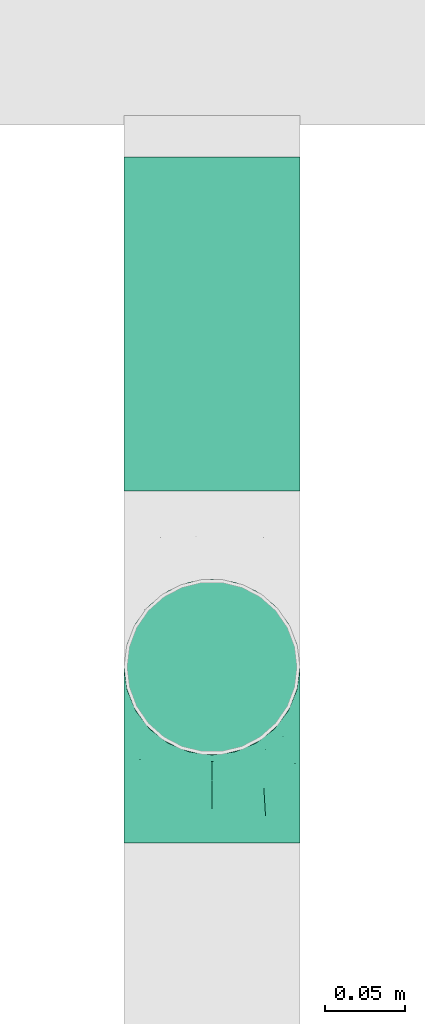
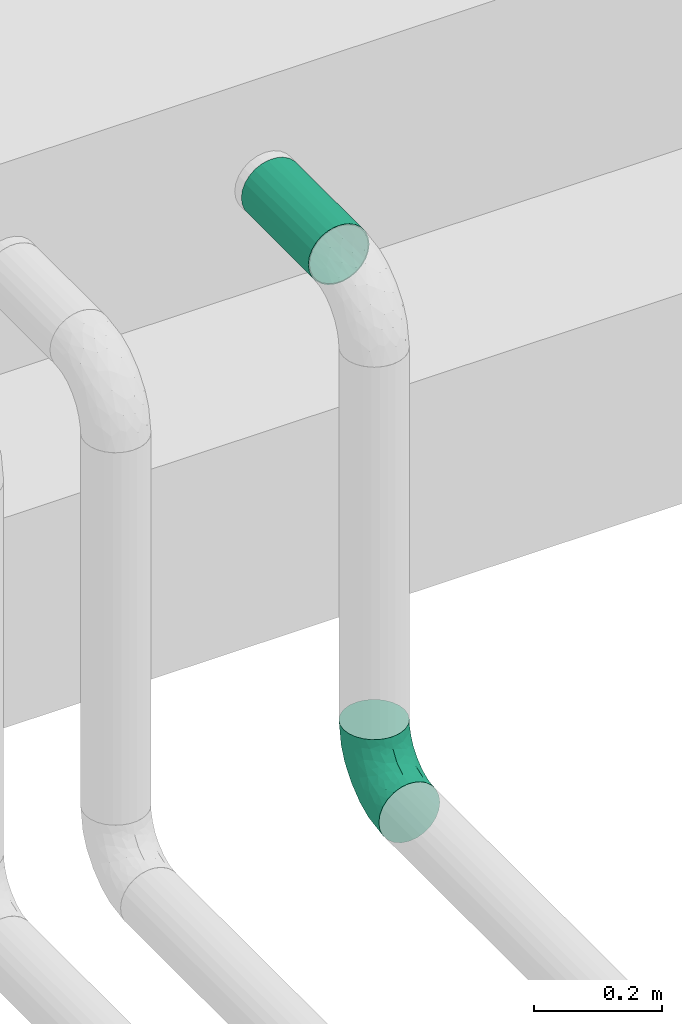
# One storey, part 58 of 91: 1 flow fitting, 1 flow segment.
"""IFC2X3 building model written with IfcOpenShell, lengths in millimetres."""

import ifcopenshell
import ifcopenshell.guid

model = None  # the IFC model being written
_history = None  # IfcOwnerHistory: only IFC2X3 demands one
_inside = {}  # id of a spatial element -> (the spatial element, [elements in it])
_under = {}  # id of a project, library or spatial element -> (it, [spatial elements below it])
_declared = {}  # id of a project -> (the project, [libraries it declares])
_typed = {}  # id of a type object -> (the type object, [elements of that type])
_made_of = {}  # id of a material, layer set ... -> (it, [elements and type objects made of it])


def new_model(schema):
    """Start an empty IFC model of exactly this schema.

    Asked for "IFC4X3", IfcOpenShell would pick the latest addendum, in which some entities
    have other attributes; the version numbers below select the first issue.
    IFC2X3 requires an IfcOwnerHistory on every rooted entity: one is made here for all.
    """
    global model, _history
    if schema == "IFC4X3":
        model = ifcopenshell.file(schema_version=(4, 3, 0, 0))
    else:
        model = ifcopenshell.file(schema=schema)
    _inside.clear()
    _under.clear()
    _declared.clear()
    _typed.clear()
    _made_of.clear()
    _history = None
    if model.schema == "IFC2X3":
        org = make("IfcOrganization", Name="unknown")
        user = make(
            "IfcPersonAndOrganization",
            ThePerson=make("IfcPerson", FamilyName="unknown"),
            TheOrganization=org,
        )
        app = make(
            "IfcApplication",
            ApplicationDeveloper=org,
            Version="unknown",
            ApplicationFullName="unknown",
            ApplicationIdentifier="unknown",
        )
        _history = make(
            "IfcOwnerHistory",
            OwningUser=user,
            OwningApplication=app,
            ChangeAction="ADDED",
            CreationDate=0,
        )
    return model


def make(cls, **values):
    """One entity of the class cls with the attributes given. An attribute that is None is left unset."""
    return model.create_entity(
        cls, **{name: value for name, value in values.items() if value is not None}
    )


def entity(cls, *values):
    """Any entity or typed value of the class cls, its attributes in the order of the schema. None: left unset."""
    e = model.create_entity(cls)
    for i, value in enumerate(values):
        if value is not None:
            e[i] = value
    return e


def rooted(cls, **values):
    """An entity with a GlobalId (a new one), such as an element, a storey or a relation."""
    return make(cls, GlobalId=ifcopenshell.guid.new(), OwnerHistory=_history, **values)


def si_unit(unit_type, name, prefix=None):
    """IfcSIUnit, for example si_unit("LENGTHUNIT", "METRE", prefix="MILLI")."""
    return make("IfcSIUnit", UnitType=unit_type, Prefix=prefix, Name=name)


def converted_unit(unit_type, name, factor, base, dimensions=None, offset=None):
    """IfcConversionBasedUnit, such as the inch: factor (a typed value) times the base unit."""
    return make(
        "IfcConversionBasedUnit"
        if offset is None
        else "IfcConversionBasedUnitWithOffset",
        ConversionOffset=offset,
        Dimensions=None
        if dimensions is None
        else entity("IfcDimensionalExponents", *dimensions),
        UnitType=unit_type,
        Name=name,
        ConversionFactor=make(
            "IfcMeasureWithUnit", ValueComponent=factor, UnitComponent=base
        ),
    )


def derived_unit(unit_type, elements):
    """IfcDerivedUnit: a product of units, each with its exponent."""
    return make(
        "IfcDerivedUnit",
        Elements=[
            make("IfcDerivedUnitElement", Unit=unit, Exponent=power)
            for unit, power in elements
        ],
        UnitType=unit_type,
    )


def assignment(units):
    """IfcUnitAssignment: the units of a project."""
    return None if units is None else make("IfcUnitAssignment", Units=units)


def point(xyz):
    """IfcCartesianPoint."""
    return None if xyz is None else make("IfcCartesianPoint", Coordinates=xyz)


def direction(xyz):
    """IfcDirection."""
    return None if xyz is None else make("IfcDirection", DirectionRatios=xyz)


def frame(location, z_axis=None, x_axis=None):
    """IfcAxis2Placement3D, a coordinate frame: its origin and axes. An axis left out is left unset."""
    return make(
        "IfcAxis2Placement3D",
        Location=point(location),
        Axis=direction(z_axis),
        RefDirection=direction(x_axis),
    )


def frame_2d(location, x_axis=None):
    """IfcAxis2Placement2D, a coordinate frame in the plane: its origin and x axis."""
    return make(
        "IfcAxis2Placement2D", Location=point(location), RefDirection=direction(x_axis)
    )


def origin_with_axes():
    """The frame at (0, 0, 0) with the z axis (0, 0, 1) and the x axis (1, 0, 0) written out."""
    return frame((0.0, 0.0, 0.0), z_axis=(0.0, 0.0, 1.0), x_axis=(1.0, 0.0, 0.0))


def origin_2d_with_axis():
    """The frame at (0, 0) in the plane with the x axis (1, 0) written out."""
    return frame_2d((0.0, 0.0), x_axis=(1.0, 0.0))


def place(relative_to, where):
    """IfcLocalPlacement: puts the frame where relative to a parent placement (None: the world)."""
    return make(
        "IfcLocalPlacement", PlacementRelTo=relative_to, RelativePlacement=where
    )


def context(
    kind, dimensions, precision=None, world=None, true_north=None, identifier=None
):
    """IfcGeometricRepresentationContext, for example the 3D "Model" context."""
    return make(
        "IfcGeometricRepresentationContext",
        ContextIdentifier=identifier,
        ContextType=kind,
        CoordinateSpaceDimension=dimensions,
        Precision=precision,
        WorldCoordinateSystem=world,
        TrueNorth=true_north,
    )


def subcontext(parent, identifier, kind, view, scale=None):
    """IfcGeometricRepresentationSubContext, for example "Body" below "Model"."""
    return make(
        "IfcGeometricRepresentationSubContext",
        ContextIdentifier=identifier,
        ContextType=kind,
        ParentContext=parent,
        TargetScale=scale,
        TargetView=view,
    )


def project(units=None, contexts=None):
    """IfcProject with its units and contexts."""
    return rooted(
        "IfcProject",
        Name="project",
        RepresentationContexts=contexts,
        UnitsInContext=assignment(units),
    )


def spatial(cls, under=None, at=None, **own):
    """A site, building, storey or space (cls), placed at a placement, below another one or the project."""
    s = rooted(cls, ObjectPlacement=at, **own)
    if under is not None:
        _under.setdefault(under.id(), (under, []))[1].append(s)
    return s


def profile(cls, at=None, kind="AREA", **sizes):
    """A parametric profile (cls). Its sizes go by their IFC names, for example OverallWidth=200.0."""
    return make(cls, ProfileType=kind, Position=at, **sizes)


def hollow_circle(**sizes):
    """IfcCircleHollowProfileDef."""
    return profile("IfcCircleHollowProfileDef", **sizes)


def extrude(swept, where, along, depth):
    """IfcExtrudedAreaSolid: the profile swept, set in the frame where, extruded along a direction by depth."""
    return make(
        "IfcExtrudedAreaSolid",
        SweptArea=swept,
        Position=where,
        ExtrudedDirection=direction(along),
        Depth=depth,
    )


def faces_of(points, faces, orient=None, outer=None):
    """IfcFace entities. A face is a list of loops; a loop is a list of indices into points, from 0.

    orient and outer hold one flag for each loop. By default every Orientation is true, the
    first loop of a face is its IfcFaceOuterBound and the others are IfcFaceBound.
    """
    made = []
    for i, loops in enumerate(faces):
        bounds = []
        for j, loop in enumerate(loops):
            is_outer = j == 0 if outer is None else outer[i][j]
            bounds.append(
                make(
                    "IfcFaceOuterBound" if is_outer else "IfcFaceBound",
                    Bound=make("IfcPolyLoop", Polygon=[points[k] for k in loop]),
                    Orientation=True if orient is None else orient[i][j],
                )
            )
        made.append(make("IfcFace", Bounds=bounds))
    return made


def open_shell(faces, orient=None, outer=None):
    """The faces of one IfcOpenShell. surface_model builds it on its shared points."""
    return ("IfcOpenShell", faces, orient, outer)


def surface_model(cls, points, shells):
    """IfcFaceBasedSurfaceModel or IfcShellBasedSurfaceModel (cls): surfaces that need not close."""
    shared = [point(p) for p in points]
    made = [make(c, CfsFaces=faces_of(shared, fs, o, b)) for c, fs, o, b in shells]
    if cls == "IfcFaceBasedSurfaceModel":
        return make(cls, FbsmFaces=made)
    return make(cls, SbsmBoundary=made)


def shape(context_of_items, identifier, shape_type, items):
    """IfcShapeRepresentation: the items that make up one representation, for example the "Body"."""
    return make(
        "IfcShapeRepresentation",
        ContextOfItems=context_of_items,
        RepresentationIdentifier=identifier,
        RepresentationType=shape_type,
        Items=items,
    )


def source(mapping_origin, context_of_items, identifier, shape_type, items):
    """IfcRepresentationMap: a shape defined once, which mapped items show again and again."""
    return make(
        "IfcRepresentationMap",
        MappingOrigin=mapping_origin,
        MappedRepresentation=shape(context_of_items, identifier, shape_type, items),
    )


def transform(
    local_origin,
    x_axis=None,
    y_axis=None,
    z_axis=None,
    scale=None,
    scale2=None,
    scale3=None,
    uniform=True,
):
    """IfcCartesianTransformationOperator3D, or its non-uniform kind. x_axis, y_axis, z_axis: its Axis1, 2, 3."""
    if uniform:
        return make(
            "IfcCartesianTransformationOperator3D",
            Axis1=direction(x_axis),
            Axis2=direction(y_axis),
            LocalOrigin=point(local_origin),
            Scale=scale,
            Axis3=direction(z_axis),
        )
    return make(
        "IfcCartesianTransformationOperator3DnonUniform",
        Axis1=direction(x_axis),
        Axis2=direction(y_axis),
        LocalOrigin=point(local_origin),
        Scale=scale,
        Axis3=direction(z_axis),
        Scale2=scale2,
        Scale3=scale3,
    )


def mapped(mapping_source, mapping_target):
    """IfcMappedItem: shows the shape of a source again, moved by a transform."""
    return make(
        "IfcMappedItem", MappingSource=mapping_source, MappingTarget=mapping_target
    )


def material(Name=None, Category=None):
    """IfcMaterial."""
    return make("IfcMaterial", Name=Name, Category=Category)


def layer(
    of_material, thickness, ventilated=None, Name=None, Category=None, Priority=None
):
    """IfcMaterialLayer: one layer of a wall or slab, of a material (None: an air gap)."""
    return make(
        "IfcMaterialLayer",
        Material=of_material,
        LayerThickness=thickness,
        IsVentilated=ventilated,
        Name=Name,
        Category=Category,
        Priority=Priority,
    )


def layer_set(layers, Name=None):
    """IfcMaterialLayerSet."""
    return make("IfcMaterialLayerSet", MaterialLayers=layers, LayerSetName=Name)


def layer_usage(for_layer_set, set_direction, sense, offset, extent=None):
    """IfcMaterialLayerSetUsage: how a layer set lies in its element."""
    return make(
        "IfcMaterialLayerSetUsage",
        ForLayerSet=for_layer_set,
        LayerSetDirection=set_direction,
        DirectionSense=sense,
        OffsetFromReferenceLine=offset,
        ReferenceExtent=extent,
    )


def made_of(thing, what):
    """Note that an element or type object is made of a material, layer set ...; save() writes the relation."""
    if what is not None:
        _made_of.setdefault(what.id(), (what, []))[1].append(thing)
    return thing


def type_object(cls, material=None, **own):
    """A type object (cls), such as IfcWallType, which elements share."""
    return made_of(rooted(cls, **own), material)


def element(
    cls,
    number,
    at=None,
    inside=None,
    cuts=None,
    type_object=None,
    material=None,
    context=None,
    identifier="Body",
    shape_type=None,
    held_by="IfcProductDefinitionShape",
    body=None,
    shapes=None,
    **own,
):
    """One element of the class cls, such as IfcWall. Its Tag is "e" and its number.

    at: its placement. inside: the storey or other place that contains it. cuts: it is an
    opening in that element (IfcRelVoidsElement). A single representation is given by context,
    identifier, shape_type and body (its items); several are given by shapes. held_by: the class
    of the entity that holds the representations. save() writes the other relations.
    """
    e = rooted(cls, Tag="e%d" % number, ObjectPlacement=at, **own)
    if body is not None:
        shapes = [shape(context, identifier, shape_type, body)]
    if shapes is not None:
        e.Representation = make(held_by, Representations=shapes)
    if inside is not None:
        _inside.setdefault(inside.id(), (inside, []))[1].append(e)
    if cuts is not None:
        rooted(
            "IfcRelVoidsElement", RelatingBuildingElement=cuts, RelatedOpeningElement=e
        )
    if type_object is not None:
        _typed.setdefault(type_object.id(), (type_object, []))[1].append(e)
    return made_of(e, material)


def aggregate(whole, parts):
    """IfcRelAggregates: a whole, such as a stair, and the parts it consists of."""
    return rooted("IfcRelAggregates", RelatingObject=whole, RelatedObjects=parts)


def save(model, path):
    """Write the relations noted so far, then the file.

    IfcRelAggregates (storeys below a building ...), IfcRelContainedInSpatialStructure (elements
    in a storey), IfcRelDefinesByType, IfcRelAssociatesMaterial and IfcRelDeclares: one each for
    every whole, place, type object, material and project.
    """
    for whole, parts in _under.values():
        aggregate(whole, parts)
    for where, things in _inside.values():
        rooted(
            "IfcRelContainedInSpatialStructure",
            RelatedElements=things,
            RelatingStructure=where,
        )
    for kind, things in _typed.values():
        rooted("IfcRelDefinesByType", RelatedObjects=things, RelatingType=kind)
    for what, things in _made_of.values():
        rooted("IfcRelAssociatesMaterial", RelatedObjects=things, RelatingMaterial=what)
    for by, libraries in _declared.values():
        rooted("IfcRelDeclares", RelatingContext=by, RelatedDefinitions=libraries)
    model.write(path)


model = new_model("IFC2X3")

# Units and contexts
model_context = context("Model", 3, precision=1e-05, world=origin_with_axes(), true_north=direction((0.0, 1.0)))
body_context = subcontext(model_context, "Body", "Model", "MODEL_VIEW")
ifc_project = project(units=[si_unit("AREAUNIT", "SQUARE_METRE"), si_unit("VOLUMEUNIT", "CUBIC_METRE", prefix="DECI"), si_unit("TIMEUNIT", "SECOND"), si_unit("THERMODYNAMICTEMPERATUREUNIT", "DEGREE_CELSIUS"), si_unit("PRESSUREUNIT", "PASCAL"), si_unit("MASSUNIT", "GRAM", prefix="KILO"), si_unit("LENGTHUNIT", "METRE", prefix="MILLI"), si_unit("POWERUNIT", "WATT"), si_unit("ELECTRICCURRENTUNIT", "AMPERE"), si_unit("ELECTRICVOLTAGEUNIT", "VOLT"), derived_unit("VOLUMETRICFLOWRATEUNIT", [(si_unit("VOLUMEUNIT", "CUBIC_METRE", prefix="DECI"), 1), (si_unit("TIMEUNIT", "SECOND"), -1)]), derived_unit("LINEARVELOCITYUNIT", [(si_unit("LENGTHUNIT", "METRE"), 1), (si_unit("TIMEUNIT", "SECOND"), -1)]), derived_unit("MASSDENSITYUNIT", [(si_unit("MASSUNIT", "GRAM", prefix="KILO"), 1), (si_unit("VOLUMEUNIT", "CUBIC_METRE"), -1)]), converted_unit("PLANEANGLEUNIT", "DEGREE", entity("IfcRatioMeasure", 0.01745), si_unit("PLANEANGLEUNIT", "RADIAN"), dimensions=[0, 0, 0, 0, 0, 0, 0])], contexts=[model_context])

# Site, building, storey
site_placement = place(None, origin_with_axes())
site = spatial("IfcSite", under=ifc_project, at=site_placement, CompositionType="ELEMENT")
building_placement = place(site_placement, origin_with_axes())
building = spatial("IfcBuilding", under=site, at=building_placement, Name="mc-building", CompositionType="ELEMENT")
storey_placement = place(building_placement, frame((0.0, 0.0, 8700.0), z_axis=(0.0, 0.0, 1.0), x_axis=(1.0, 0.0, 0.0)))
storey = spatial("IfcBuildingStorey", under=building, at=storey_placement, CompositionType="ELEMENT", Elevation=8700.0)

# Flow fitting
duct_fitting_type = type_object("IfcDuctFittingType", Name="BU", PredefinedType="BEND")
shared_shape_1 = source(origin_with_axes(), body_context, "Body", "SurfaceModel", [
    surface_model("IfcShellBasedSurfaceModel", [(-110.0, 0.0, -55.0), (-110.0, -14.23505, -53.12592), (-110.0, 14.23505, -53.12592), (-110.0, 53.12592, 14.23505), (-110.0, 27.5, -47.63139), (-110.0, 38.89087, -38.89087), (-110.0, -55.0, 0.0), (-110.0, -53.12592, 14.23505), (-110.0, -38.89087, -38.89087), (-110.0, -27.5, -47.63139), (-110.0, -53.12592, -14.23505), (-110.0, -47.63139, -27.5), (-110.0, -14.23505, 53.12592), (-110.0, 14.23505, 53.12592), (-110.0, 27.5, 47.63139), (-110.0, -47.63139, 27.5), (-110.0, -38.89087, 38.89087), (-110.0, -27.5, 47.63139), (-110.0, 0.0, 55.0), (-110.0, 55.0, 0.0), (-110.0, 53.12592, -14.23505), (-110.0, 47.63139, -27.5), (-110.0, 47.63139, 27.5), (-110.0, 38.89087, 38.89087), (-14.23505, 110.0, -53.12592), (-55.0, 110.0, 0.0), (0.0, 110.0, -55.0), (-27.5, 110.0, -47.63139), (-38.89087, 110.0, -38.89087), (-47.63139, 110.0, -27.5), (38.89087, 110.0, -38.89087), (53.12592, 110.0, 14.23505), (27.5, 110.0, -47.63139), (14.23505, 110.0, -53.12592), (47.63139, 110.0, -27.5), (53.12592, 110.0, -14.23505), (55.0, 110.0, 0.0), (-53.12592, 110.0, -14.23505), (-53.12592, 110.0, 14.23505), (-47.63139, 110.0, 27.5), (-38.89087, 110.0, 38.89087), (-27.5, 110.0, 47.63139), (0.0, 110.0, 55.0), (-14.23505, 110.0, 53.12592), (38.89087, 110.0, 38.89087), (47.63139, 110.0, 27.5), (27.5, 110.0, 47.63139), (14.23505, 110.0, 53.12592), (-64.21732, 48.68956, 43.63444), (-76.6405, 38.18013, 45.55988), (-60.44912, 32.56953, 51.94617), (-76.00813, 5.38378, 55.0), (-90.15553, 11.94394, 54.09138), (-78.5998, 26.77405, 50.81338), (-70.18771, 18.55163, 54.03432), (-75.55424, 54.2118, 32.41257), (-93.27622, 45.77614, 33.48188), (-96.12334, 22.13664, 50.81337), (-21.00813, 45.34362, 55.0), (-18.36258, 70.48427, 54.04484), (-32.04182, 59.64019, 52.24446), (-63.88653, 74.77858, 17.99134), (-74.66383, 63.08407, 19.92123), (-63.60674, 66.07878, 29.97482), (-99.597, 52.72185, 18.52927), (-93.11138, 56.59448, 10.50359), (-98.21577, 57.34403, 0.0), (-53.42855, 92.60092, 21.04759), (-88.54852, 54.8376, 21.04759), (-11.86161, 90.23965, 54.10313), (-5.38378, 76.00813, 55.0), (-57.34403, 98.21577, 0.0), (-56.64619, 93.12774, 10.22088), (-45.34362, 21.00813, 55.0), (-44.60838, 44.60838, 52.13415), (-92.68484, 35.46673, 43.63443), (-22.25266, 95.40765, 50.81337), (-35.97783, 90.61597, 43.63443), (-43.70931, 69.58671, 44.47149), (-27.23711, 77.39884, 50.81337), (-57.2828, 79.3123, 24.9774), (-58.67786, 84.31125, 16.04456), (-82.93277, 60.36161, 12.91784), (-49.88337, 54.51816, 47.224), (-74.57753, 66.83759, 9.55742), (-45.35812, 94.97281, 33.48188), (-59.18663, 88.95241, 0.0), (-51.517, 78.6292, 33.48188), (-65.14788, 80.03077, 0.0), (-56.45322, 62.06476, 39.63545), (-88.95241, 59.18663, 0.0), (-71.10913, 71.10913, 0.0), (-80.03077, 65.14788, 0.0), (-94.9309, 45.36788, -33.48188), (-93.11358, 56.60141, -10.46614), (-99.64997, 52.79499, -18.30015), (-90.20425, 36.08686, -43.63443), (-79.99933, 46.56772, -37.92748), (-76.00813, 5.38378, -55.0), (-72.75364, 19.68651, -53.60527), (-45.34362, 21.00813, -55.0), (-21.91957, 65.12078, -53.85897), (-5.38378, 76.00813, -55.0), (-21.00813, 45.34362, -55.0), (-35.41876, 92.89265, -43.63443), (-91.10309, 11.02766, -54.21832), (-45.77614, 93.27622, -33.48188), (-90.50474, 23.21022, -50.81337), (-70.92854, 33.31794, -49.51754), (-78.52933, 63.35627, -11.73997), (-24.91508, 84.05606, -50.81337), (-88.78941, 54.74452, -21.04759), (-69.59921, 57.34866, -33.48187), (-73.36422, 62.46673, -22.94182), (-63.49062, 67.59111, -28.46929), (-56.59448, 93.11138, -10.50359), (-54.8376, 88.54852, -21.04759), (-54.10679, 75.85581, -32.31867), (-57.75956, 31.09612, -52.80882), (-52.72185, 99.597, -18.52927), (-12.62913, 89.46304, -53.99097), (-34.46825, 66.46123, -50.04329), (-43.9837, 43.9837, -52.42279), (-65.78527, 72.58348, -17.68796), (-70.34468, 43.65295, -44.21951), (-57.47001, 51.99467, -44.91465), (-60.72547, 82.29174, -12.88567), (-42.34915, 74.24548, -43.63444), (-57.25194, 63.5016, -38.08211), (-80.95344, 53.56991, -29.32027), (-52.32891, 4.55257, -54.0482), (32.52942, 47.13398, -30.48571), (14.88266, 20.92917, -33.7947), (14.95561, 36.05775, -42.26543), (30.24048, 70.09027, -41.7461), (19.3559, 65.35825, -48.00507), (-70.35075, -46.44478, -19.5952), (-47.13398, -32.52942, -30.48571), (-28.49299, -30.5778, -16.4009), (-4.55257, 52.32891, -54.0482), (-22.4954, 22.4954, -53.25347), (-75.47368, -11.22546, -52.60718), (-81.32209, -51.5606, -9.98467), (-80.81763, -41.84862, -32.14655), (-70.09027, -30.24048, -41.7461), (-36.05774, -14.95561, -42.26543), (-9.15831, -10.852, -27.8997), (-65.35825, -19.3559, -48.00507), (11.22546, 75.47368, -52.60718), (3.94376, 43.9333, -50.53315), (-13.39742, 13.39743, -48.13058), (-43.9333, -3.94376, -50.53315), (49.37776, 67.29486, 0.0), (41.8609, 47.82256, -9.92641), (50.20582, 74.51695, -9.9731), (18.93131, 11.7156, -17.56239), (-27.5, -32.89419, 0.0), (-1.23348, -12.25375, -12.18106), (41.84862, 80.81763, -32.14655), (35.70604, 41.31408, -20.38235), (46.44478, 70.35075, -19.5952), (32.89419, 27.5, 0.0), (6.67262, -6.67262, 0.0), (-67.29486, -49.37776, 0.0), (-50.36265, -42.95545, -9.51562), (-5.47251, 5.47251, -39.92906), (-70.35075, -46.44478, 19.5952), (-74.51695, -50.20582, 9.9731), (-41.31407, -35.70604, 20.38235), (-47.13398, -32.52942, 30.48571), (-80.81763, -41.84862, 32.14655), (-4.55257, 52.32891, 54.0482), (11.22546, 75.47368, 52.60718), (-43.9333, -3.94376, 50.53315), (-65.35825, -19.3559, 48.00507), (-36.05774, -14.95561, 42.26543), (-70.09027, -30.24048, 41.7461), (-11.7156, -18.93131, 17.56239), (30.5778, 28.49299, 16.4009), (12.25375, 1.23348, 12.18106), (51.5606, 81.32209, 9.98467), (42.95545, 50.36265, 9.51562), (-75.47368, -11.22546, 52.60718), (-52.32891, 4.55257, 54.0482), (3.94376, 43.9333, 50.53315), (-22.4954, 22.4954, 53.25347), (-13.39742, 13.39743, 48.13058), (10.852, 9.15831, 27.8997), (-20.92916, -14.88266, 33.79469), (-47.82256, -41.8609, 9.92641), (32.52942, 47.13398, 30.48571), (46.44478, 70.35075, 19.5952), (41.84862, 80.81763, 32.14655), (30.24048, 70.09027, 41.7461), (19.3559, 65.35825, 48.00507), (14.95561, 36.05775, 42.26543), (-5.47251, 5.47251, 39.92906)], [open_shell([[[0, 1, 2]], [[2, 3, 4]], [[4, 3, 5]], [[2, 6, 7]], [[8, 6, 9]], [[1, 9, 6]], [[10, 6, 11]], [[8, 11, 6]], [[6, 2, 1]], [[12, 13, 14]], [[15, 2, 7]], [[16, 17, 2]], [[2, 17, 12]], [[12, 18, 13]], [[19, 20, 3]], [[5, 3, 21]], [[20, 21, 3]], [[22, 3, 2]], [[23, 22, 2]], [[12, 14, 2]], [[2, 14, 23]], [[15, 16, 2]], [[24, 25, 26]], [[27, 25, 24]], [[25, 28, 29]], [[28, 25, 27]], [[30, 26, 31]], [[26, 30, 32]], [[32, 33, 26]], [[34, 31, 35]], [[31, 34, 30]], [[35, 31, 36]], [[29, 37, 25]], [[38, 39, 26]], [[39, 40, 26]], [[41, 42, 40]], [[42, 26, 40]], [[42, 41, 43]], [[26, 44, 45]], [[31, 26, 45]], [[26, 46, 44]], [[47, 46, 26]], [[42, 47, 26]], [[25, 38, 26]], [[48, 49, 50]], [[18, 51, 52]], [[53, 54, 50]], [[55, 56, 49]], [[56, 22, 23]], [[13, 57, 14]], [[58, 59, 60]], [[61, 62, 63]], [[3, 64, 65]], [[53, 52, 54]], [[3, 65, 66]], [[67, 39, 38]], [[56, 68, 64]], [[65, 64, 68]], [[69, 59, 70]], [[38, 71, 72]], [[73, 58, 74]], [[75, 49, 56]], [[76, 69, 43]], [[53, 57, 52]], [[77, 78, 79]], [[41, 76, 43]], [[43, 69, 42]], [[55, 68, 56]], [[23, 14, 75]], [[76, 77, 79]], [[80, 67, 81]], [[62, 82, 68]], [[60, 78, 83]], [[62, 84, 82]], [[85, 77, 40]], [[81, 67, 72]], [[86, 72, 71]], [[87, 85, 67]], [[61, 81, 88]], [[77, 41, 40]], [[78, 77, 87]], [[23, 75, 56]], [[83, 89, 48]], [[85, 40, 39]], [[62, 68, 55]], [[89, 87, 63]], [[83, 48, 50]], [[57, 75, 14]], [[49, 75, 53]], [[67, 85, 39]], [[87, 77, 85]], [[63, 62, 55]], [[89, 55, 48]], [[80, 63, 87]], [[66, 65, 90]], [[66, 19, 3]], [[84, 91, 92]], [[92, 90, 82]], [[65, 82, 90]], [[61, 84, 62]], [[92, 82, 84]], [[68, 82, 65]], [[3, 22, 64]], [[56, 64, 22]], [[38, 25, 71]], [[81, 72, 86]], [[38, 72, 67]], [[91, 61, 88]], [[80, 81, 61]], [[63, 80, 61]], [[67, 80, 87]], [[77, 76, 41]], [[79, 59, 69]], [[79, 69, 76]], [[42, 69, 70]], [[60, 59, 79]], [[58, 70, 59]], [[78, 60, 79]], [[58, 60, 74]], [[52, 57, 13]], [[75, 57, 53]], [[18, 52, 13]], [[52, 51, 54]], [[51, 73, 54]], [[50, 73, 74]], [[73, 50, 54]], [[50, 74, 83]], [[60, 83, 74]], [[89, 83, 78]], [[87, 89, 78]], [[55, 89, 63]], [[50, 49, 53]], [[55, 49, 48]], [[81, 86, 88]], [[91, 84, 61]], [[5, 21, 93]], [[90, 94, 66]], [[20, 94, 95]], [[96, 93, 97]], [[98, 99, 100]], [[96, 4, 5]], [[101, 102, 103]], [[28, 27, 104]], [[2, 105, 0]], [[104, 106, 28]], [[99, 105, 107]], [[108, 107, 96]], [[90, 109, 94]], [[107, 2, 4]], [[20, 66, 94]], [[27, 24, 110]], [[109, 111, 94]], [[112, 113, 114]], [[37, 115, 71]], [[116, 106, 117]], [[99, 118, 100]], [[116, 115, 119]], [[37, 119, 115]], [[24, 120, 110]], [[121, 110, 101]], [[119, 106, 116]], [[101, 110, 120]], [[122, 103, 100]], [[117, 123, 116]], [[124, 125, 108]], [[115, 116, 126]], [[106, 29, 28]], [[26, 102, 120]], [[127, 104, 110]], [[97, 124, 96]], [[125, 122, 118]], [[128, 127, 125]], [[96, 5, 93]], [[115, 126, 86]], [[117, 106, 127]], [[111, 113, 129]], [[95, 93, 21]], [[97, 129, 112]], [[110, 104, 27]], [[106, 104, 127]], [[96, 107, 4]], [[99, 107, 108]], [[99, 108, 118]], [[105, 99, 98]], [[112, 114, 128]], [[121, 125, 127]], [[20, 19, 66]], [[109, 90, 92]], [[94, 111, 95]], [[91, 123, 109]], [[129, 113, 112]], [[93, 95, 111]], [[21, 20, 95]], [[71, 115, 86]], [[71, 25, 37]], [[123, 91, 88]], [[126, 116, 123]], [[123, 88, 126]], [[86, 126, 88]], [[37, 29, 119]], [[106, 119, 29]], [[129, 93, 111]], [[124, 112, 125]], [[0, 105, 98]], [[107, 105, 2]], [[125, 118, 108]], [[100, 118, 122]], [[93, 129, 97]], [[113, 111, 109]], [[109, 123, 113]], [[114, 123, 117]], [[123, 114, 113]], [[128, 114, 117]], [[127, 128, 117]], [[112, 128, 125]], [[103, 122, 101]], [[110, 121, 127]], [[101, 122, 121]], [[125, 121, 122]], [[26, 120, 24]], [[101, 120, 102]], [[96, 124, 108]], [[92, 91, 109]], [[112, 124, 97]], [[100, 130, 98]], [[131, 132, 133]], [[32, 134, 135]], [[136, 137, 138]], [[139, 140, 103]], [[98, 141, 0]], [[142, 10, 136]], [[143, 144, 137]], [[6, 10, 142]], [[137, 145, 146]], [[144, 147, 145]], [[143, 136, 11]], [[11, 136, 10]], [[8, 143, 11]], [[148, 149, 139]], [[8, 9, 144]], [[9, 1, 147]], [[130, 141, 98]], [[103, 140, 100]], [[148, 135, 149]], [[150, 151, 140]], [[152, 153, 154]], [[130, 140, 151]], [[148, 26, 33]], [[147, 1, 141]], [[155, 146, 132]], [[156, 138, 157]], [[134, 30, 158]], [[150, 140, 149]], [[158, 30, 34]], [[30, 134, 32]], [[153, 159, 160]], [[131, 160, 159]], [[144, 145, 137]], [[36, 152, 154]], [[146, 138, 137]], [[155, 161, 162]], [[158, 160, 131]], [[133, 149, 135]], [[156, 163, 164]], [[163, 142, 164]], [[139, 103, 102]], [[153, 152, 161]], [[34, 35, 160]], [[162, 157, 155]], [[132, 165, 133]], [[157, 146, 155]], [[140, 130, 100]], [[141, 130, 151]], [[141, 151, 147]], [[141, 1, 0]], [[102, 26, 148]], [[140, 139, 149]], [[102, 148, 139]], [[135, 33, 32]], [[151, 150, 145]], [[9, 147, 144]], [[151, 145, 147]], [[145, 165, 146]], [[135, 148, 33]], [[133, 135, 134]], [[131, 133, 134]], [[133, 165, 150]], [[133, 150, 149]], [[145, 150, 165]], [[132, 131, 159]], [[146, 165, 132]], [[160, 158, 34]], [[134, 158, 131]], [[144, 143, 8]], [[136, 143, 137]], [[155, 153, 161]], [[154, 153, 160]], [[153, 155, 159]], [[132, 159, 155]], [[160, 35, 154]], [[36, 154, 35]], [[164, 136, 138]], [[6, 142, 163]], [[136, 164, 142]], [[156, 164, 138]], [[156, 157, 162]], [[146, 157, 138]], [[15, 7, 166]], [[6, 163, 167]], [[168, 169, 166]], [[166, 169, 170]], [[171, 172, 70]], [[173, 174, 175]], [[17, 176, 174]], [[177, 156, 162]], [[176, 16, 170]], [[170, 16, 15]], [[161, 178, 179]], [[152, 180, 181]], [[182, 173, 183]], [[18, 12, 182]], [[184, 185, 186]], [[183, 185, 73]], [[183, 73, 51]], [[177, 187, 188]], [[189, 168, 166]], [[187, 178, 190]], [[16, 176, 17]], [[161, 152, 181]], [[45, 191, 31]], [[45, 44, 192]], [[192, 191, 45]], [[180, 36, 31]], [[193, 194, 195]], [[46, 47, 194]], [[193, 195, 190]], [[193, 44, 46]], [[172, 42, 70]], [[185, 58, 73]], [[189, 163, 156]], [[163, 189, 167]], [[70, 58, 171]], [[184, 171, 185]], [[169, 188, 175]], [[180, 31, 191]], [[192, 193, 190]], [[191, 190, 178]], [[182, 174, 173]], [[194, 47, 172]], [[190, 195, 187]], [[186, 185, 173]], [[162, 179, 177]], [[188, 196, 175]], [[179, 187, 177]], [[185, 171, 58]], [[172, 171, 184]], [[172, 184, 194]], [[172, 47, 42]], [[51, 18, 182]], [[185, 183, 173]], [[51, 182, 183]], [[174, 12, 17]], [[184, 186, 195]], [[46, 194, 193]], [[184, 195, 194]], [[195, 196, 187]], [[174, 182, 12]], [[175, 174, 176]], [[169, 175, 176]], [[175, 196, 186]], [[175, 186, 173]], [[195, 186, 196]], [[188, 169, 168]], [[187, 196, 188]], [[166, 170, 15]], [[176, 170, 169]], [[193, 192, 44]], [[191, 192, 190]], [[177, 189, 156]], [[167, 189, 166]], [[189, 177, 168]], [[188, 168, 177]], [[166, 7, 167]], [[6, 167, 7]], [[181, 191, 178]], [[36, 180, 152]], [[191, 181, 180]], [[161, 181, 178]], [[161, 179, 162]], [[187, 179, 178]]])]),
])
flow_fitting_placement = place(storey_placement, frame((30518.54047, 2612.35324, 415.0), z_axis=(1.0, 0.0, 0.0), x_axis=(0.0, 1.0, 0.0)))
element("IfcFlowFitting", 1, at=flow_fitting_placement, inside=storey, type_object=duct_fitting_type, Name="BU", context=body_context, shape_type="MappedRepresentation", body=[
    mapped(shared_shape_1, transform((0.0, 0.0, 0.0), scale=1.0)),
])

# Flow segment
ifc_material = material(Name="FZ1")
ifc_layer = layer(ifc_material, 0.0)
ifc_layer_set = layer_set([ifc_layer], Name="FZ1")
ifc_layer_usage = layer_usage(ifc_layer_set, "AXIS1", "POSITIVE", 0.0)
duct_segment_type = type_object("IfcDuctSegmentType", PredefinedType="RIGIDSEGMENT")
shared_shape_2 = source(origin_with_axes(), body_context, "Body", "SweptSolid", [
    extrude(hollow_circle(Radius=55.0, WallThickness=2.0, at=origin_2d_with_axis()), frame((0.0, 0.0, 0.0), z_axis=(1.0, 0.0, 0.0), x_axis=(0.0, 1.0, 0.0)), (0.0, 0.0, 1.0), 208.9),
])
flow_segment_placement = place(storey_placement, frame((30518.54047, 2931.20513, 1344.0), z_axis=(0.0, 0.0, 1.0), x_axis=(0.0, -1.0, 0.0)))
element("IfcFlowSegment", 2, at=flow_segment_placement, inside=storey, type_object=duct_segment_type, material=ifc_layer_usage, context=body_context, shape_type="MappedRepresentation", body=[
    mapped(shared_shape_2, transform((0.0, 0.0, 0.0), scale=1.0)),
])

save(model, "model.ifc")
